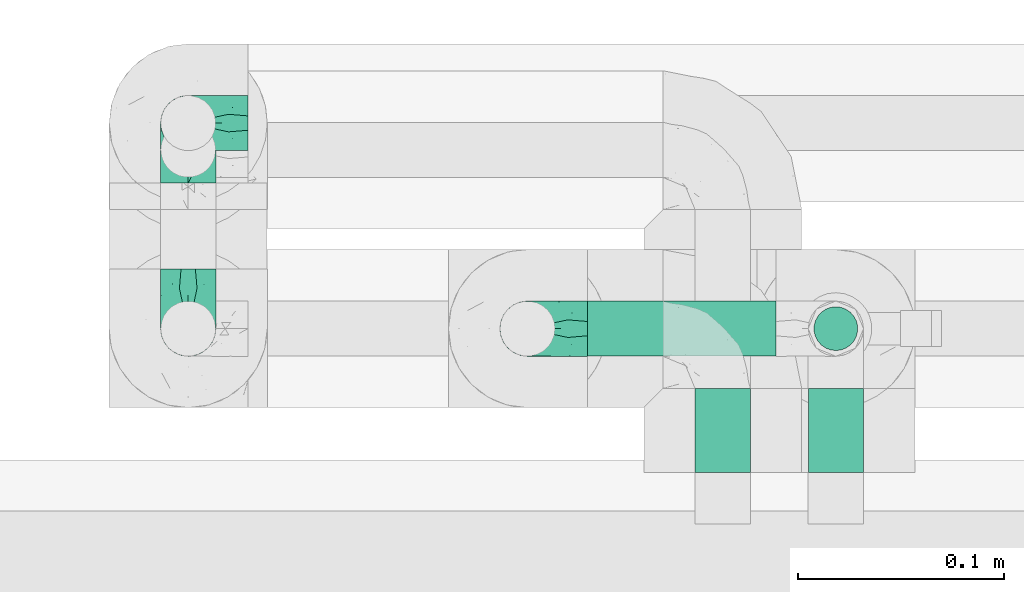
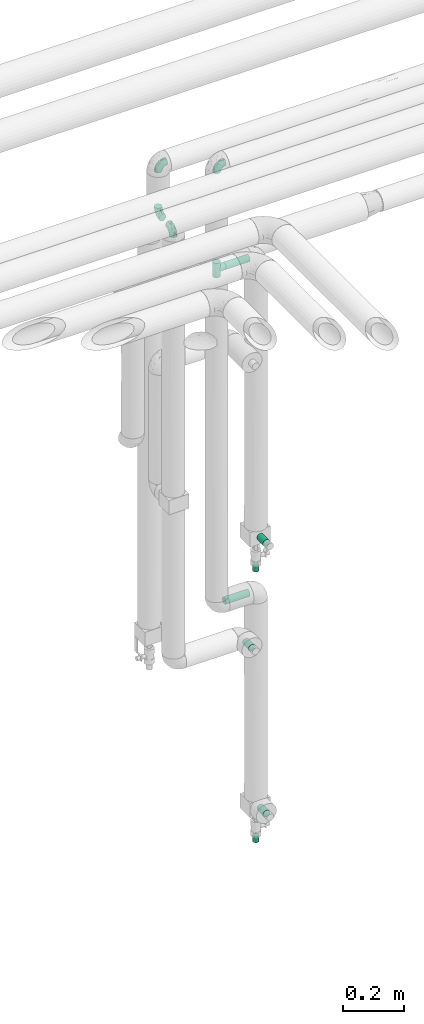
# One storey, part 759 of 827: 7 flow fittings, 5 flow segments.
"""IFC2X3 building model written with IfcOpenShell, lengths in millimetres."""

import ifcopenshell
import ifcopenshell.guid

model = None  # the IFC model being written
_history = None  # IfcOwnerHistory: only IFC2X3 demands one
_inside = {}  # id of a spatial element -> (the spatial element, [elements in it])
_under = {}  # id of a project, library or spatial element -> (it, [spatial elements below it])
_declared = {}  # id of a project -> (the project, [libraries it declares])
_typed = {}  # id of a type object -> (the type object, [elements of that type])
_made_of = {}  # id of a material, layer set ... -> (it, [elements and type objects made of it])


def new_model(schema):
    """Start an empty IFC model of exactly this schema.

    Asked for "IFC4X3", IfcOpenShell would pick the latest addendum, in which some entities
    have other attributes; the version numbers below select the first issue.
    IFC2X3 requires an IfcOwnerHistory on every rooted entity: one is made here for all.
    """
    global model, _history
    if schema == "IFC4X3":
        model = ifcopenshell.file(schema_version=(4, 3, 0, 0))
    else:
        model = ifcopenshell.file(schema=schema)
    _inside.clear()
    _under.clear()
    _declared.clear()
    _typed.clear()
    _made_of.clear()
    _history = None
    if model.schema == "IFC2X3":
        org = make("IfcOrganization", Name="unknown")
        user = make(
            "IfcPersonAndOrganization",
            ThePerson=make("IfcPerson", FamilyName="unknown"),
            TheOrganization=org,
        )
        app = make(
            "IfcApplication",
            ApplicationDeveloper=org,
            Version="unknown",
            ApplicationFullName="unknown",
            ApplicationIdentifier="unknown",
        )
        _history = make(
            "IfcOwnerHistory",
            OwningUser=user,
            OwningApplication=app,
            ChangeAction="ADDED",
            CreationDate=0,
        )
    return model


def make(cls, **values):
    """One entity of the class cls with the attributes given. An attribute that is None is left unset."""
    return model.create_entity(
        cls, **{name: value for name, value in values.items() if value is not None}
    )


def entity(cls, *values):
    """Any entity or typed value of the class cls, its attributes in the order of the schema. None: left unset."""
    e = model.create_entity(cls)
    for i, value in enumerate(values):
        if value is not None:
            e[i] = value
    return e


def rooted(cls, **values):
    """An entity with a GlobalId (a new one), such as an element, a storey or a relation."""
    return make(cls, GlobalId=ifcopenshell.guid.new(), OwnerHistory=_history, **values)


def si_unit(unit_type, name, prefix=None):
    """IfcSIUnit, for example si_unit("LENGTHUNIT", "METRE", prefix="MILLI")."""
    return make("IfcSIUnit", UnitType=unit_type, Prefix=prefix, Name=name)


def converted_unit(unit_type, name, factor, base, dimensions=None, offset=None):
    """IfcConversionBasedUnit, such as the inch: factor (a typed value) times the base unit."""
    return make(
        "IfcConversionBasedUnit"
        if offset is None
        else "IfcConversionBasedUnitWithOffset",
        ConversionOffset=offset,
        Dimensions=None
        if dimensions is None
        else entity("IfcDimensionalExponents", *dimensions),
        UnitType=unit_type,
        Name=name,
        ConversionFactor=make(
            "IfcMeasureWithUnit", ValueComponent=factor, UnitComponent=base
        ),
    )


def derived_unit(unit_type, elements):
    """IfcDerivedUnit: a product of units, each with its exponent."""
    return make(
        "IfcDerivedUnit",
        Elements=[
            make("IfcDerivedUnitElement", Unit=unit, Exponent=power)
            for unit, power in elements
        ],
        UnitType=unit_type,
    )


def assignment(units):
    """IfcUnitAssignment: the units of a project."""
    return None if units is None else make("IfcUnitAssignment", Units=units)


def point(xyz):
    """IfcCartesianPoint."""
    return None if xyz is None else make("IfcCartesianPoint", Coordinates=xyz)


def direction(xyz):
    """IfcDirection."""
    return None if xyz is None else make("IfcDirection", DirectionRatios=xyz)


def frame(location, z_axis=None, x_axis=None):
    """IfcAxis2Placement3D, a coordinate frame: its origin and axes. An axis left out is left unset."""
    return make(
        "IfcAxis2Placement3D",
        Location=point(location),
        Axis=direction(z_axis),
        RefDirection=direction(x_axis),
    )


def frame_2d(location, x_axis=None):
    """IfcAxis2Placement2D, a coordinate frame in the plane: its origin and x axis."""
    return make(
        "IfcAxis2Placement2D", Location=point(location), RefDirection=direction(x_axis)
    )


def origin():
    """The frame at (0, 0, 0) with its axes left unset."""
    return frame((0.0, 0.0, 0.0))


def origin_2d_with_axis():
    """The frame at (0, 0) in the plane with the x axis (1, 0) written out."""
    return frame_2d((0.0, 0.0), x_axis=(1.0, 0.0))


def place(relative_to, where):
    """IfcLocalPlacement: puts the frame where relative to a parent placement (None: the world)."""
    return make(
        "IfcLocalPlacement", PlacementRelTo=relative_to, RelativePlacement=where
    )


def context(
    kind, dimensions, precision=None, world=None, true_north=None, identifier=None
):
    """IfcGeometricRepresentationContext, for example the 3D "Model" context."""
    return make(
        "IfcGeometricRepresentationContext",
        ContextIdentifier=identifier,
        ContextType=kind,
        CoordinateSpaceDimension=dimensions,
        Precision=precision,
        WorldCoordinateSystem=world,
        TrueNorth=true_north,
    )


def subcontext(parent, identifier, kind, view, scale=None):
    """IfcGeometricRepresentationSubContext, for example "Body" below "Model"."""
    return make(
        "IfcGeometricRepresentationSubContext",
        ContextIdentifier=identifier,
        ContextType=kind,
        ParentContext=parent,
        TargetScale=scale,
        TargetView=view,
    )


def project(units=None, contexts=None):
    """IfcProject with its units and contexts."""
    return rooted(
        "IfcProject",
        Name="project",
        RepresentationContexts=contexts,
        UnitsInContext=assignment(units),
    )


def spatial(cls, under=None, at=None, **own):
    """A site, building, storey or space (cls), placed at a placement, below another one or the project."""
    s = rooted(cls, ObjectPlacement=at, **own)
    if under is not None:
        _under.setdefault(under.id(), (under, []))[1].append(s)
    return s


def profile(cls, at=None, kind="AREA", **sizes):
    """A parametric profile (cls). Its sizes go by their IFC names, for example OverallWidth=200.0."""
    return make(cls, ProfileType=kind, Position=at, **sizes)


def circle(**sizes):
    """IfcCircleProfileDef."""
    return profile("IfcCircleProfileDef", **sizes)


def extrude(swept, where, along, depth):
    """IfcExtrudedAreaSolid: the profile swept, set in the frame where, extruded along a direction by depth."""
    return make(
        "IfcExtrudedAreaSolid",
        SweptArea=swept,
        Position=where,
        ExtrudedDirection=direction(along),
        Depth=depth,
    )


def faces_of(points, faces, orient=None, outer=None):
    """IfcFace entities. A face is a list of loops; a loop is a list of indices into points, from 0.

    orient and outer hold one flag for each loop. By default every Orientation is true, the
    first loop of a face is its IfcFaceOuterBound and the others are IfcFaceBound.
    """
    made = []
    for i, loops in enumerate(faces):
        bounds = []
        for j, loop in enumerate(loops):
            is_outer = j == 0 if outer is None else outer[i][j]
            bounds.append(
                make(
                    "IfcFaceOuterBound" if is_outer else "IfcFaceBound",
                    Bound=make("IfcPolyLoop", Polygon=[points[k] for k in loop]),
                    Orientation=True if orient is None else orient[i][j],
                )
            )
        made.append(make("IfcFace", Bounds=bounds))
    return made


def faceted_brep(points, faces, orient=None, outer=None, voids=None):
    """IfcFacetedBrep: a solid bounded by flat faces; with voids (closed shells), ...WithVoids."""
    shared = [point(p) for p in points]
    hull = make("IfcClosedShell", CfsFaces=faces_of(shared, faces, orient, outer))
    if voids is None:
        return make("IfcFacetedBrep", Outer=hull)
    return make(
        "IfcFacetedBrepWithVoids",
        Outer=hull,
        Voids=[
            make(cls, CfsFaces=faces_of(shared, fs, o, b)) for cls, fs, o, b in voids
        ],
    )


def shape(context_of_items, identifier, shape_type, items):
    """IfcShapeRepresentation: the items that make up one representation, for example the "Body"."""
    return make(
        "IfcShapeRepresentation",
        ContextOfItems=context_of_items,
        RepresentationIdentifier=identifier,
        RepresentationType=shape_type,
        Items=items,
    )


def source(mapping_origin, context_of_items, identifier, shape_type, items):
    """IfcRepresentationMap: a shape defined once, which mapped items show again and again."""
    return make(
        "IfcRepresentationMap",
        MappingOrigin=mapping_origin,
        MappedRepresentation=shape(context_of_items, identifier, shape_type, items),
    )


def transform(
    local_origin,
    x_axis=None,
    y_axis=None,
    z_axis=None,
    scale=None,
    scale2=None,
    scale3=None,
    uniform=True,
):
    """IfcCartesianTransformationOperator3D, or its non-uniform kind. x_axis, y_axis, z_axis: its Axis1, 2, 3."""
    if uniform:
        return make(
            "IfcCartesianTransformationOperator3D",
            Axis1=direction(x_axis),
            Axis2=direction(y_axis),
            LocalOrigin=point(local_origin),
            Scale=scale,
            Axis3=direction(z_axis),
        )
    return make(
        "IfcCartesianTransformationOperator3DnonUniform",
        Axis1=direction(x_axis),
        Axis2=direction(y_axis),
        LocalOrigin=point(local_origin),
        Scale=scale,
        Axis3=direction(z_axis),
        Scale2=scale2,
        Scale3=scale3,
    )


def mapped(mapping_source, mapping_target):
    """IfcMappedItem: shows the shape of a source again, moved by a transform."""
    return make(
        "IfcMappedItem", MappingSource=mapping_source, MappingTarget=mapping_target
    )


def material(Name=None, Category=None):
    """IfcMaterial."""
    return make("IfcMaterial", Name=Name, Category=Category)


def made_of(thing, what):
    """Note that an element or type object is made of a material, layer set ...; save() writes the relation."""
    if what is not None:
        _made_of.setdefault(what.id(), (what, []))[1].append(thing)
    return thing


def type_object(cls, material=None, **own):
    """A type object (cls), such as IfcWallType, which elements share."""
    return made_of(rooted(cls, **own), material)


def type_shapes(of_type, sources):
    """Give a type object the sources (RepresentationMaps) that its elements show as mapped items."""
    of_type.RepresentationMaps = sources


def element(
    cls,
    number,
    at=None,
    inside=None,
    cuts=None,
    type_object=None,
    material=None,
    context=None,
    identifier="Body",
    shape_type=None,
    held_by="IfcProductDefinitionShape",
    body=None,
    shapes=None,
    **own,
):
    """One element of the class cls, such as IfcWall. Its Tag is "e" and its number.

    at: its placement. inside: the storey or other place that contains it. cuts: it is an
    opening in that element (IfcRelVoidsElement). A single representation is given by context,
    identifier, shape_type and body (its items); several are given by shapes. held_by: the class
    of the entity that holds the representations. save() writes the other relations.
    """
    e = rooted(cls, Tag="e%d" % number, ObjectPlacement=at, **own)
    if body is not None:
        shapes = [shape(context, identifier, shape_type, body)]
    if shapes is not None:
        e.Representation = make(held_by, Representations=shapes)
    if inside is not None:
        _inside.setdefault(inside.id(), (inside, []))[1].append(e)
    if cuts is not None:
        rooted(
            "IfcRelVoidsElement", RelatingBuildingElement=cuts, RelatedOpeningElement=e
        )
    if type_object is not None:
        _typed.setdefault(type_object.id(), (type_object, []))[1].append(e)
    return made_of(e, material)


def aggregate(whole, parts):
    """IfcRelAggregates: a whole, such as a stair, and the parts it consists of."""
    return rooted("IfcRelAggregates", RelatingObject=whole, RelatedObjects=parts)


def save(model, path):
    """Write the relations noted so far, then the file.

    IfcRelAggregates (storeys below a building ...), IfcRelContainedInSpatialStructure (elements
    in a storey), IfcRelDefinesByType, IfcRelAssociatesMaterial and IfcRelDeclares: one each for
    every whole, place, type object, material and project.
    """
    for whole, parts in _under.values():
        aggregate(whole, parts)
    for where, things in _inside.values():
        rooted(
            "IfcRelContainedInSpatialStructure",
            RelatedElements=things,
            RelatingStructure=where,
        )
    for kind, things in _typed.values():
        rooted("IfcRelDefinesByType", RelatedObjects=things, RelatingType=kind)
    for what, things in _made_of.values():
        rooted("IfcRelAssociatesMaterial", RelatedObjects=things, RelatingMaterial=what)
    for by, libraries in _declared.values():
        rooted("IfcRelDeclares", RelatingContext=by, RelatedDefinitions=libraries)
    model.write(path)


model = new_model("IFC2X3")

# Units and contexts
model_context = context("Model", 3, precision=0.01, world=origin(), true_north=direction((6.12303176911189e-17, 1.0)))
body_context = subcontext(model_context, "Body", "Model", "MODEL_VIEW")
ifc_project = project(units=[si_unit("LENGTHUNIT", "METRE", prefix="MILLI"), si_unit("AREAUNIT", "SQUARE_METRE"), si_unit("VOLUMEUNIT", "CUBIC_METRE"), converted_unit("PLANEANGLEUNIT", "DEGREE", entity("IfcRatioMeasure", 0.0174532925199433), si_unit("PLANEANGLEUNIT", "RADIAN"), dimensions=[0, 0, 0, 0, 0, 0, 0]), si_unit("MASSUNIT", "GRAM", prefix="KILO"), derived_unit("MASSDENSITYUNIT", [(si_unit("MASSUNIT", "GRAM", prefix="KILO"), 1), (si_unit("LENGTHUNIT", "METRE"), -3)]), derived_unit("MOMENTOFINERTIAUNIT", [(si_unit("LENGTHUNIT", "METRE"), 4)]), si_unit("TIMEUNIT", "SECOND"), si_unit("FREQUENCYUNIT", "HERTZ"), si_unit("THERMODYNAMICTEMPERATUREUNIT", "DEGREE_CELSIUS"), derived_unit("THERMALTRANSMITTANCEUNIT", [(si_unit("MASSUNIT", "GRAM", prefix="KILO"), 1), (si_unit("THERMODYNAMICTEMPERATUREUNIT", "KELVIN"), -1), (si_unit("TIMEUNIT", "SECOND"), -3)]), derived_unit("VOLUMETRICFLOWRATEUNIT", [(si_unit("LENGTHUNIT", "METRE"), 3), (si_unit("TIMEUNIT", "SECOND"), -1)]), derived_unit("MASSFLOWRATEUNIT", [(si_unit("MASSUNIT", "GRAM", prefix="KILO"), 1), (si_unit("TIMEUNIT", "SECOND"), -1)]), derived_unit("ROTATIONALFREQUENCYUNIT", [(si_unit("TIMEUNIT", "SECOND"), -1)]), si_unit("ELECTRICCURRENTUNIT", "AMPERE"), si_unit("ELECTRICVOLTAGEUNIT", "VOLT"), si_unit("POWERUNIT", "WATT"), si_unit("FORCEUNIT", "NEWTON", prefix="KILO"), si_unit("ILLUMINANCEUNIT", "LUX"), si_unit("LUMINOUSFLUXUNIT", "LUMEN"), si_unit("LUMINOUSINTENSITYUNIT", "CANDELA"), derived_unit("USERDEFINED", [(si_unit("MASSUNIT", "GRAM", prefix="KILO"), -1), (si_unit("LENGTHUNIT", "METRE"), -2), (si_unit("TIMEUNIT", "SECOND"), 3), (si_unit("LUMINOUSFLUXUNIT", "LUMEN"), 1)]), derived_unit("LINEARVELOCITYUNIT", [(si_unit("LENGTHUNIT", "METRE"), 1), (si_unit("TIMEUNIT", "SECOND"), -1)]), si_unit("PRESSUREUNIT", "PASCAL"), derived_unit("USERDEFINED", [(si_unit("LENGTHUNIT", "METRE"), -2), (si_unit("MASSUNIT", "GRAM", prefix="KILO"), 1), (si_unit("TIMEUNIT", "SECOND"), -2)]), derived_unit("LINEARFORCEUNIT", [(si_unit("MASSUNIT", "GRAM", prefix="KILO"), 1), (si_unit("LENGTHUNIT", "METRE"), 1), (si_unit("TIMEUNIT", "SECOND"), -2), (si_unit("LENGTHUNIT", "METRE"), -1)]), derived_unit("PLANARFORCEUNIT", [(si_unit("MASSUNIT", "GRAM", prefix="KILO"), 1), (si_unit("LENGTHUNIT", "METRE"), 1), (si_unit("TIMEUNIT", "SECOND"), -2), (si_unit("LENGTHUNIT", "METRE"), -2)])], contexts=[model_context])

# Site, building, storey
site_placement = place(None, origin())
site = spatial("IfcSite", under=ifc_project, at=site_placement, CompositionType="ELEMENT")
building_placement = place(site_placement, origin())
building = spatial("IfcBuilding", under=site, at=building_placement, CompositionType="ELEMENT")
storey_placement = place(building_placement, frame((0.0, 0.0, 28200.0)))
storey = spatial("IfcBuildingStorey", under=building, at=storey_placement, Name="08", CompositionType="ELEMENT", Elevation=28200.0)

# Flow segments
pipe_segment_type = type_object("IfcPipeSegmentType", PredefinedType="NOTDEFINED")
flow_segment_1_placement = place(storey_placement, frame((34719.52, 18319.92, 1215.0)))
element("IfcFlowSegment", 1, at=flow_segment_1_placement, inside=storey, type_object=pipe_segment_type, context=body_context, shape_type="SweptSolid", body=[
    extrude(circle(Radius=13.4, at=origin_2d_with_axis()), frame((0.0, 15.0, 15.0), z_axis=(1.0, 0.0, 0.0), x_axis=(0.0, 1.0, 0.0)), (0.0, 0.0, 1.0), 91.8000000000181),
])
flow_segment_2_placement = place(storey_placement, frame((34770.39, 18264.91, 1045.0)))
element("IfcFlowSegment", 2, at=flow_segment_2_placement, inside=storey, type_object=pipe_segment_type, context=body_context, shape_type="SweptSolid", body=[
    extrude(circle(Radius=13.4, at=origin_2d_with_axis()), frame((15.0, 0.0, 15.0), z_axis=(0.0, 1.0, 0.0), x_axis=(-1.0, 0.0, 0.0)), (0.0, 0.0, 1.0), 40.9000000000037),
])
flow_segment_3_placement = place(storey_placement, frame((34825.43, 18264.91, 357.0)))
element("IfcFlowSegment", 3, at=flow_segment_3_placement, inside=storey, type_object=pipe_segment_type, context=body_context, shape_type="SweptSolid", body=[
    extrude(circle(Radius=13.4, at=origin_2d_with_axis()), frame((15.0, 0.0, 15.0), z_axis=(0.0, 1.0, 0.0), x_axis=(-1.0, 0.0, 0.0)), (0.0, 0.0, 1.0), 40.9999999999993),
])
flow_segment_4_placement = place(storey_placement, frame((34825.43, 18264.91, 1448.5)))
element("IfcFlowSegment", 4, at=flow_segment_4_placement, inside=storey, type_object=pipe_segment_type, context=body_context, shape_type="SweptSolid", body=[
    extrude(circle(Radius=13.4, at=origin_2d_with_axis()), frame((15.0, 0.0, 15.0), z_axis=(0.0, 1.0, 0.0), x_axis=(-1.0, 0.0, 0.0)), (0.0, 0.0, 1.0), 40.9999999999928),
])
flow_segment_5_placement = place(storey_placement, frame((34719.42, 18319.92, 2565.0)))
element("IfcFlowSegment", 5, at=flow_segment_5_placement, inside=storey, type_object=pipe_segment_type, context=body_context, shape_type="SweptSolid", body=[
    extrude(circle(Radius=13.4, at=origin_2d_with_axis()), frame((0.0, 15.0, 15.0), z_axis=(1.0, 0.0, 0.0), x_axis=(0.0, 1.0, 0.0)), (0.0, 0.0, 1.0), 91.9000000000224),
])

# Flow fittings
ifc_material = material()
pipe_fitting_type_1 = type_object("IfcPipeFittingType", PredefinedType="NOTDEFINED", material=ifc_material)
shared_shape_1 = source(origin(), body_context, "Body", "SweptSolid", [
    extrude(circle(Radius=10.65, at=origin_2d_with_axis()), frame((0.0, 0.0, 0.0), z_axis=(1.0, 0.0, 0.0), x_axis=(0.0, 1.0, 0.0)), (0.0, 0.0, 1.0), 25.0000000000003),
])
type_shapes(pipe_fitting_type_1, [shared_shape_1])
for number, where, z_axis, x_axis in (
    (6, (34840.42, 18334.91, 244.0), (1.0, 0.0, 0.0), (0.0, 0.0, -1.0)),
    (7, (34840.42, 18334.91, 1335.5), (1.0, 0.0, 0.0), (0.0, 0.0, -1.0)),
):
    element("IfcFlowFitting", number, at=place(storey_placement, frame(where, z_axis=z_axis, x_axis=x_axis)), inside=storey, type_object=pipe_fitting_type_1, material=ifc_material, context=body_context, shape_type="MappedRepresentation", body=[
        mapped(shared_shape_1, transform((0.0, 0.0, 0.0), scale=1.0)),
    ])
pipe_fitting_type_2 = type_object("IfcPipeFittingType", Name="ADSK_1", PredefinedType="NOTDEFINED", material=ifc_material)
shared_shape_2 = source(origin(), body_context, "Body", "Brep", [
    faceted_brep([(-29.1, 0.0, -13.45), (-29.1, -3.48, -12.99), (-29.1, -6.73, -11.65), (-29.1, -9.51, -9.51), (-29.1, -11.65, -6.73), (-29.1, -12.99, -3.48), (-29.1, -13.45, 0.0), (-29.1, -12.99, 3.48), (-29.1, -11.65, 6.72), (-29.1, -9.51, 9.51), (-29.1, -6.73, 11.65), (-29.1, -3.48, 12.99), (-29.1, 0.0, 13.45), (-29.1, 3.48, 12.99), (-29.1, 6.72, 11.65), (-29.1, 9.51, 9.51), (-29.1, 11.65, 6.72), (-29.1, 12.99, 3.48), (-29.1, 13.45, 0.0), (-29.1, 12.99, -3.48), (-29.1, 11.65, -6.73), (-29.1, 9.51, -9.51), (-29.1, 6.72, -11.65), (-29.1, 3.48, -12.99), (-3.48, 29.1, -12.99), (-6.72, 29.1, -11.65), (-9.51, 29.1, -9.51), (-11.65, 29.1, -6.73), (-12.99, 29.1, -3.48), (-13.45, 29.1, 0.0), (-12.99, 29.1, 3.48), (-11.65, 29.1, 6.72), (-9.51, 29.1, 9.51), (-6.72, 29.1, 11.65), (-3.48, 29.1, 12.99), (0.0, 29.1, 13.45), (3.48, 29.1, 12.99), (6.73, 29.1, 11.65), (9.51, 29.1, 9.51), (11.65, 29.1, 6.72), (12.99, 29.1, 3.48), (13.45, 29.1, 0.0), (12.99, 29.1, -3.48), (11.65, 29.1, -6.73), (9.51, 29.1, -9.51), (6.73, 29.1, -11.65), (3.48, 29.1, -12.99), (0.0, 29.1, -13.45), (-19.62, -11.66, 4.28), (-21.41, -10.36, 7.6), (-16.26, -10.01, 0.0), (-12.48, -9.76, 2.75), (-10.66, 15.6, 11.91), (-15.27, 9.55, 12.42), (-10.71, 10.71, 13.09), (-0.04, 0.04, 0.0), (0.49, -0.45, 4.38), (-3.67, -4.15, 4.26), (-22.68, -11.73, 0.0), (-21.45, -4.97, 12.13), (-11.59, -2.84, 11.28), (-14.77, 0.17, 13.07), (-19.08, -7.58, 10.06), (-22.36, -1.69, 13.23), (-20.49, 2.21, 13.42), (-7.82, -7.75, 0.0), (-5.53, -2.55, 8.58), (-1.33, -0.87, 6.53), (-1.15, 1.15, 8.49), (-22.46, 5.38, 12.69), (-14.04, 21.05, 6.04), (-3.19, 3.19, 11.14), (-5.08, 25.05, 12.59), (-1.97, 21.79, 13.41), (-22.68, 11.31, 8.78), (-18.16, 12.64, 9.68), (-20.46, 14.33, 6.11), (-4.13, 10.11, 13.26), (-7.66, 3.08, 12.63), (-2.02, 8.24, 12.45), (-24.91, 8.22, 10.95), (-5.08, 14.28, 13.42), (-8.96, 6.48, 13.4), (-19.7, 16.14, 3.1), (-18.03, 18.03, 0.0), (-23.05, 15.96, 0.0), (-25.26, 12.69, 5.56), (4.97, 21.45, 12.13), (7.58, 19.08, 10.06), (1.69, 22.36, 13.23), (10.36, 21.41, 7.6), (8.11, 12.69, 6.86), (11.66, 19.62, 4.28), (-6.03, 19.65, 12.79), (9.76, 12.48, 2.75), (10.01, 16.26, 0.0), (-14.58, 16.06, 9.44), (-11.19, 23.14, 8.74), (-16.29, 16.8, 7.24), (-11.99, -5.68, 9.36), (-15.42, 20.78, 3.08), (5.79, 12.02, 9.27), (2.84, 11.59, 11.28), (2.55, 5.53, 8.58), (-15.74, 23.57, 0.0), (-15.96, 23.05, 0.0), (-24.62, 13.88, 2.39), (-8.61, 22.49, 11.12), (-14.98, 12.8, 11.14), (11.73, 22.68, 0.0), (-12.69, -8.11, 6.86), (7.75, 7.82, 0.0), (-15.98, 6.12, 13.19), (-14.48, 3.64, 13.45), (-19.6, 9.46, 11.31), (-8.3, 15.02, 12.85), (-0.17, 14.77, 13.07), (-6.9, -5.2, 6.52), (7.5, 8.93, 4.46), (5.22, 6.95, 6.56), (-8.85, -7.47, 4.42), (3.86, 3.93, 0.0), (4.18, 3.75, 4.31), (-23.57, 15.74, 0.0), (-3.93, -3.86, 0.0), (-21.79, 1.97, -13.41), (-11.31, 22.68, -8.78), (-14.33, 20.46, -6.11), (-12.69, 25.26, -5.56), (4.97, 21.45, -12.13), (2.84, 11.59, -11.28), (-0.17, 14.77, -13.07), (-25.05, 5.08, -12.59), (-16.8, 16.29, -7.24), (-20.78, 15.42, -3.08), (-16.14, 19.7, -3.1), (-12.02, -5.79, -9.27), (-11.59, -2.84, -11.28), (-5.53, -2.55, -8.58), (-23.14, 11.19, -8.74), (-22.49, 8.61, -11.12), (-1.33, -0.87, -6.53), (-3.67, -4.15, -4.26), (-6.9, -5.2, -6.52), (-19.65, 6.03, -12.79), (-15.6, 10.66, -11.91), (-14.28, 5.08, -13.42), (-10.71, 10.71, -13.09), (-6.48, 8.96, -13.4), (-19.62, -11.66, -4.28), (-21.41, -10.36, -7.6), (-12.48, -9.76, -2.75), (11.66, 19.62, -4.28), (-12.69, -8.11, -6.86), (-22.36, -1.69, -13.23), (-16.06, 14.58, -9.44), (5.68, 11.99, -9.36), (7.58, 19.08, -10.06), (-19.08, -7.58, -10.06), (-21.45, -4.97, -12.13), (-9.55, 15.27, -12.42), (-12.8, 14.98, -11.14), (-8.22, 24.91, -10.95), (10.36, 21.41, -7.6), (-5.38, 22.46, -12.69), (1.69, 22.36, -13.23), (-2.21, 20.49, -13.42), (-12.64, 18.16, -9.68), (-21.05, 14.04, -6.04), (9.76, 12.48, -2.75), (-10.11, 4.13, -13.26), (-3.08, 7.66, -12.63), (-8.24, 2.02, -12.45), (-13.88, 24.62, -2.39), (8.11, 12.69, -6.86), (-6.12, 15.98, -13.19), (-3.64, 14.48, -13.45), (-9.46, 19.6, -11.31), (-15.02, 8.3, -12.85), (-14.77, 0.17, -13.07), (-3.19, 3.19, -11.14), (5.22, 6.95, -6.56), (2.55, 5.53, -8.58), (0.49, -0.45, -4.38), (4.18, 3.75, -4.31), (-8.85, -7.47, -4.42), (-1.15, 1.15, -8.49), (7.5, 8.93, -4.46)], [[[0, 1, 2, 3, 4, 5, 6, 7, 8, 9, 10, 11, 12, 13, 14, 15, 16, 17, 18, 19, 20, 21, 22, 23]], [[24, 25, 26, 27, 28, 29, 30, 31, 32, 33, 34, 35, 36, 37, 38, 39, 40, 41, 42, 43, 44, 45, 46, 47]], [[48, 49, 8]], [[48, 50, 51]], [[52, 53, 54]], [[55, 56, 57]], [[49, 9, 8]], [[58, 48, 7]], [[59, 60, 61]], [[62, 10, 9]], [[62, 59, 10]], [[12, 63, 64]], [[51, 50, 65]], [[66, 67, 68]], [[12, 11, 63]], [[69, 14, 13]], [[31, 30, 70]], [[66, 71, 60]], [[34, 72, 73]], [[74, 75, 76]], [[77, 78, 79]], [[14, 80, 15]], [[16, 15, 74]], [[81, 54, 82]], [[83, 84, 85]], [[74, 76, 86]], [[37, 87, 88]], [[88, 38, 37]], [[36, 35, 89]], [[90, 91, 92]], [[93, 81, 73]], [[35, 34, 73]], [[10, 59, 11]], [[92, 94, 95]], [[96, 97, 98]], [[90, 92, 39]], [[99, 60, 62]], [[40, 39, 92]], [[87, 37, 36]], [[100, 84, 83]], [[50, 48, 58]], [[100, 83, 98]], [[101, 102, 103]], [[104, 105, 84, 100, 29]], [[48, 8, 7]], [[86, 17, 16]], [[106, 18, 17]], [[32, 97, 107]], [[53, 52, 108]], [[52, 93, 107]], [[97, 96, 107]], [[72, 107, 93]], [[72, 34, 33]], [[92, 109, 40]], [[33, 32, 107]], [[69, 13, 64]], [[88, 87, 102]], [[12, 64, 13]], [[49, 110, 62]], [[39, 38, 90]], [[95, 94, 111]], [[112, 113, 82]], [[53, 69, 112]], [[80, 74, 15]], [[114, 108, 75]], [[32, 31, 97]], [[115, 52, 54]], [[93, 115, 81]], [[89, 73, 116]], [[106, 76, 83]], [[106, 83, 85]], [[83, 76, 98]], [[100, 30, 29]], [[60, 59, 62]], [[63, 59, 61]], [[110, 117, 99]], [[60, 71, 78]], [[89, 87, 36]], [[116, 79, 102]], [[116, 102, 87]], [[102, 71, 103]], [[110, 49, 48]], [[62, 9, 49]], [[38, 88, 90]], [[91, 90, 88]], [[112, 69, 64]], [[80, 69, 114]], [[111, 94, 118]], [[119, 101, 103]], [[117, 66, 99]], [[117, 120, 57]], [[119, 91, 101]], [[66, 68, 71]], [[66, 117, 67]], [[121, 111, 122, 55]], [[56, 55, 122]], [[31, 70, 97]], [[97, 70, 98]], [[107, 96, 52]], [[53, 108, 114]], [[112, 82, 54]], [[116, 73, 81]], [[78, 82, 61]], [[81, 82, 77]], [[73, 89, 35]], [[87, 89, 116]], [[59, 63, 11]], [[64, 63, 61]], [[112, 64, 113]], [[53, 112, 54]], [[7, 6, 58]], [[109, 92, 95]], [[109, 41, 40]], [[69, 53, 114]], [[52, 96, 108]], [[75, 108, 96]], [[75, 96, 98]], [[114, 75, 74]], [[64, 61, 113]], [[61, 82, 113]], [[91, 88, 101]], [[110, 48, 51]], [[92, 91, 94]], [[91, 119, 118]], [[106, 85, 123, 18]], [[106, 17, 86]], [[60, 78, 61]], [[79, 78, 71]], [[102, 79, 71]], [[77, 79, 116]], [[81, 77, 116]], [[78, 77, 82]], [[69, 80, 14]], [[74, 80, 114]], [[74, 86, 16]], [[106, 86, 76]], [[107, 72, 33]], [[73, 72, 93]], [[98, 70, 100]], [[75, 98, 76]], [[30, 100, 70]], [[110, 99, 62]], [[66, 60, 99]], [[120, 110, 51]], [[67, 117, 57]], [[57, 56, 67]], [[67, 122, 119]], [[110, 120, 117]], [[65, 120, 51]], [[57, 65, 124, 55]], [[122, 67, 56]], [[67, 103, 68]], [[71, 68, 103]], [[65, 57, 120]], [[102, 101, 88]], [[67, 119, 103]], [[118, 119, 122]], [[118, 122, 111]], [[91, 118, 94]], [[81, 115, 54]], [[93, 52, 115]], [[23, 125, 0]], [[126, 127, 128]], [[129, 130, 131]], [[23, 22, 132]], [[133, 134, 135]], [[136, 137, 138]], [[21, 139, 140]], [[141, 142, 143]], [[144, 140, 145]], [[143, 136, 138]], [[146, 147, 148]], [[144, 132, 140]], [[5, 4, 149]], [[4, 3, 150]], [[45, 129, 46]], [[151, 50, 149]], [[152, 43, 42]], [[42, 41, 109]], [[150, 149, 4]], [[153, 149, 150]], [[154, 1, 0]], [[139, 155, 140]], [[156, 130, 157]], [[149, 58, 5]], [[18, 123, 85, 84, 134]], [[158, 159, 137]], [[84, 105, 135]], [[160, 145, 161]], [[143, 153, 136]], [[27, 26, 126]], [[25, 162, 26]], [[152, 163, 43]], [[25, 24, 164]], [[47, 165, 166]], [[158, 3, 2]], [[167, 127, 126]], [[20, 19, 168]], [[47, 46, 165]], [[44, 157, 45]], [[23, 132, 125]], [[44, 43, 163]], [[158, 2, 159]], [[47, 166, 24]], [[129, 45, 157]], [[164, 24, 166]], [[134, 84, 135]], [[95, 169, 152]], [[22, 21, 140]], [[144, 146, 125]], [[109, 152, 42]], [[95, 152, 109]], [[170, 171, 172]], [[155, 139, 133]], [[28, 27, 128]], [[159, 2, 1]], [[173, 29, 28]], [[50, 151, 65]], [[169, 95, 111]], [[163, 174, 157]], [[175, 176, 148]], [[160, 164, 175]], [[162, 126, 26]], [[177, 161, 167]], [[21, 20, 139]], [[144, 145, 178]], [[144, 178, 146]], [[154, 125, 179]], [[173, 127, 135]], [[173, 135, 105]], [[135, 127, 133]], [[134, 19, 18]], [[154, 159, 1]], [[179, 172, 137]], [[179, 137, 159]], [[137, 180, 138]], [[130, 129, 157]], [[165, 129, 131]], [[174, 181, 156]], [[130, 180, 171]], [[3, 158, 150]], [[153, 150, 158]], [[174, 163, 152]], [[157, 44, 163]], [[175, 164, 166]], [[162, 164, 177]], [[130, 182, 180]], [[181, 141, 182]], [[55, 183, 184]], [[65, 151, 185]], [[183, 55, 142]], [[156, 181, 182]], [[180, 182, 186]], [[181, 187, 184]], [[65, 142, 55, 124]], [[20, 168, 139]], [[139, 168, 133]], [[140, 155, 145]], [[160, 161, 177]], [[175, 148, 147]], [[179, 125, 146]], [[171, 148, 131]], [[146, 148, 170]], [[125, 154, 0]], [[159, 154, 179]], [[129, 165, 46]], [[166, 165, 131]], [[175, 166, 176]], [[160, 175, 147]], [[58, 149, 50]], [[58, 6, 5]], [[145, 160, 147]], [[164, 160, 177]], [[145, 155, 161]], [[167, 161, 155]], [[167, 155, 133]], [[177, 167, 126]], [[166, 131, 176]], [[131, 148, 176]], [[149, 153, 151]], [[153, 143, 185]], [[145, 147, 178]], [[174, 152, 169]], [[173, 105, 104, 29]], [[173, 28, 128]], [[130, 171, 131]], [[172, 171, 180]], [[137, 172, 180]], [[170, 172, 179]], [[146, 170, 179]], [[171, 170, 148]], [[164, 162, 25]], [[126, 162, 177]], [[126, 128, 27]], [[173, 128, 127]], [[140, 132, 22]], [[125, 132, 144]], [[133, 168, 134]], [[167, 133, 127]], [[19, 134, 168]], [[153, 158, 136]], [[137, 136, 158]], [[141, 143, 138]], [[185, 143, 142]], [[186, 141, 138]], [[183, 142, 141]], [[185, 142, 65]], [[153, 185, 151]], [[180, 186, 138]], [[182, 141, 186]], [[141, 184, 183]], [[184, 111, 121, 55]], [[174, 156, 157]], [[182, 130, 156]], [[187, 174, 169]], [[141, 181, 184]], [[174, 187, 181]], [[111, 187, 169]], [[111, 184, 187]], [[146, 178, 147]]]),
])
type_shapes(pipe_fitting_type_2, [shared_shape_2])
for number, where, z_axis, x_axis, name in (
    (8, (34525.39, 18334.91, 2800.0), (-1.0, 0.0, 0.0), (0.0, 0.0, 1.0), "ADSK_1"),
    (9, (34525.39, 18434.91, 2800.0), (1.0, 0.0, 0.0), (0.0, 1.0, 0.0), "ADSK_1"),
    (10, (34525.39, 18434.91, 3000.17), (0.0, 1.0, 0.0), (0.0, 0.0, 1.0), "ADSK_1"),
    (11, (34690.42, 18334.91, 3000.17), (0.0, 1.0, 0.0), (0.0, 0.0, 1.0), "ADSK_1"),
):
    element("IfcFlowFitting", number, at=place(storey_placement, frame(where, z_axis=z_axis, x_axis=x_axis)), inside=storey, type_object=pipe_fitting_type_2, material=ifc_material, Name=name, ObjectType="ADSK_1", context=body_context, shape_type="MappedRepresentation", body=[
        mapped(shared_shape_2, transform((0.0, 0.0, 0.0), scale=1.0)),
    ])
pipe_fitting_type_3 = type_object("IfcPipeFittingType", Name="ADSK_1", PredefinedType="NOTDEFINED", material=ifc_material)
shared_shape_3 = source(origin(), body_context, "Body", "Brep", [
    faceted_brep([(-29.0, 3.48, -12.99), (-29.0, 0.0, -13.45), (-29.0, -3.48, -12.99), (-29.0, -6.73, -11.65), (-29.0, -9.51, -9.51), (-29.0, -11.65, -6.73), (-29.0, -12.99, -3.48), (-29.0, -13.45, 0.0), (-29.0, -12.99, 3.48), (-29.0, -11.65, 6.72), (-29.0, -9.51, 9.51), (-29.0, -6.73, 11.65), (-29.0, -3.48, 12.99), (-29.0, 0.0, 13.45), (-29.0, 3.48, 12.99), (-29.0, 6.72, 11.65), (-29.0, 9.51, 9.51), (-29.0, 11.65, 6.72), (-29.0, 12.99, 3.48), (-29.0, 13.45, 0.0), (-29.0, 12.99, -3.48), (-29.0, 11.65, -6.73), (-29.0, 9.51, -9.51), (-29.0, 6.72, -11.65), (29.0, 11.65, -6.73), (29.0, 12.99, -3.48), (29.0, 13.45, 0.0), (29.0, 12.99, 3.48), (29.0, 11.65, 6.72), (29.0, 9.51, 9.51), (29.0, 6.72, 11.65), (29.0, 3.48, 12.99), (29.0, 0.0, 13.45), (29.0, -3.48, 12.99), (29.0, -6.73, 11.65), (29.0, -9.51, 9.51), (29.0, -11.65, 6.72), (29.0, -12.99, 3.48), (29.0, -13.45, 0.0), (29.0, -12.99, -3.48), (29.0, -11.65, -6.73), (29.0, -9.51, -9.51), (29.0, -6.73, -11.65), (29.0, -3.48, -12.99), (29.0, 0.0, -13.45), (29.0, 3.48, -12.99), (29.0, 6.72, -11.65), (29.0, 9.51, -9.51), (12.96, -12.96, 3.59), (13.45, -13.45, 0.0), (-13.45, -13.45, 0.0), (11.64, -11.64, 6.74), (7.54, -7.54, 11.14), (9.76, -9.76, 9.25), (-12.96, -12.96, 3.59), (-11.64, -11.64, 6.74), (-9.76, -9.76, 9.25), (-7.54, -7.54, 11.14), (-5.12, -5.12, 12.44), (5.12, -5.12, 12.44), (2.58, -2.58, 13.2), (0.0, 0.0, 13.45), (-2.58, -2.58, 13.2), (2.58, -2.58, -13.2), (0.0, 0.0, -13.45), (-2.58, -2.58, -13.2), (-5.12, -5.12, -12.44), (5.12, -5.12, -12.44), (7.54, -7.54, -11.14), (9.76, -9.76, -9.25), (11.64, -11.64, -6.74), (12.96, -12.96, -3.59), (-7.54, -7.54, -11.14), (-9.76, -9.76, -9.25), (-12.96, -12.96, -3.59), (-11.64, -11.64, -6.74), (-12.99, -29.0, -3.48), (-11.65, -29.0, -6.73), (-9.51, -29.0, -9.51), (-6.72, -29.0, -11.65), (-3.48, -29.0, -12.99), (0.0, -29.0, -13.45), (3.48, -29.0, -12.99), (6.73, -29.0, -11.65), (9.51, -29.0, -9.51), (11.65, -29.0, -6.73), (12.99, -29.0, -3.48), (13.45, -29.0, 0.0), (12.99, -29.0, 3.48), (11.65, -29.0, 6.72), (9.51, -29.0, 9.51), (6.73, -29.0, 11.65), (3.48, -29.0, 12.99), (0.0, -29.0, 13.45), (-3.48, -29.0, 12.99), (-6.72, -29.0, 11.65), (-9.51, -29.0, 9.51), (-11.65, -29.0, 6.72), (-12.99, -29.0, 3.48), (-13.45, -29.0, 0.0)], [[[0, 1, 2, 3, 4, 5, 6, 7, 8, 9, 10, 11, 12, 13, 14, 15, 16, 17, 18, 19, 20, 21, 22, 23]], [[24, 25, 26, 27, 28, 29, 30, 31, 32, 33, 34, 35, 36, 37, 38, 39, 40, 41, 42, 43, 44, 45, 46, 47]], [[37, 36, 48]], [[38, 37, 49]], [[50, 8, 7]], [[49, 37, 48]], [[36, 51, 48]], [[35, 34, 52]], [[51, 36, 53]], [[52, 53, 35]], [[53, 36, 35]], [[50, 54, 8]], [[8, 54, 9]], [[54, 55, 9]], [[56, 57, 10]], [[10, 9, 56]], [[10, 57, 11]], [[56, 9, 55]], [[11, 57, 58]], [[52, 34, 59]], [[60, 32, 61]], [[62, 61, 13]], [[59, 33, 60]], [[33, 59, 34]], [[60, 33, 32]], [[61, 32, 31, 14, 13]], [[28, 27, 18, 17]], [[16, 15, 30, 29]], [[17, 16, 29, 28]], [[31, 30, 15, 14]], [[19, 18, 27, 26]], [[62, 12, 58]], [[12, 62, 13]], [[58, 12, 11]], [[47, 22, 21, 24]], [[25, 20, 19, 26]], [[25, 24, 21, 20]], [[23, 22, 47, 46]], [[44, 43, 63]], [[44, 64, 1, 0, 45]], [[64, 44, 63]], [[1, 64, 65]], [[46, 45, 0, 23]], [[65, 66, 2]], [[1, 65, 2]], [[66, 3, 2]], [[63, 43, 67]], [[42, 41, 68]], [[69, 68, 41]], [[40, 70, 69]], [[69, 41, 40]], [[42, 68, 67]], [[39, 38, 49]], [[6, 50, 7]], [[39, 71, 40]], [[71, 39, 49]], [[40, 71, 70]], [[72, 3, 66]], [[72, 4, 3]], [[4, 72, 73]], [[4, 73, 5]], [[74, 50, 6]], [[75, 74, 5]], [[74, 6, 5]], [[75, 5, 73]], [[42, 67, 43]], [[76, 77, 78, 79, 80, 81, 82, 83, 84, 85, 86, 87, 88, 89, 90, 91, 92, 93, 94, 95, 96, 97, 98, 99]], [[99, 98, 50]], [[54, 50, 98]], [[96, 95, 57]], [[97, 96, 56]], [[97, 54, 98]], [[58, 95, 94]], [[55, 54, 97]], [[56, 55, 97]], [[58, 57, 95]], [[93, 61, 62]], [[58, 94, 62]], [[56, 96, 57]], [[62, 94, 93]], [[60, 93, 92]], [[91, 59, 92]], [[89, 88, 48]], [[53, 90, 89]], [[52, 91, 90]], [[49, 88, 87]], [[59, 60, 92]], [[52, 59, 91]], [[49, 48, 88]], [[51, 53, 89]], [[48, 51, 89]], [[52, 90, 53]], [[93, 60, 61]], [[87, 86, 49]], [[71, 49, 86]], [[69, 85, 84]], [[68, 84, 83]], [[86, 85, 71]], [[67, 83, 82]], [[70, 71, 85]], [[69, 70, 85]], [[67, 68, 83]], [[81, 64, 63]], [[67, 82, 63]], [[69, 84, 68]], [[63, 82, 81]], [[65, 81, 80]], [[79, 66, 80]], [[77, 76, 74]], [[73, 78, 77]], [[72, 79, 78]], [[50, 76, 99]], [[66, 65, 80]], [[72, 66, 79]], [[50, 74, 76]], [[75, 73, 77]], [[74, 75, 77]], [[72, 78, 73]], [[81, 65, 64]]]),
])
type_shapes(pipe_fitting_type_3, [shared_shape_3])
flow_fitting_placement = place(storey_placement, frame((34690.42, 18334.91, 2580.0), z_axis=(0.0, 1.0, 0.0), x_axis=(0.0, 0.0, -1.0)))
element("IfcFlowFitting", 12, at=flow_fitting_placement, inside=storey, type_object=pipe_fitting_type_3, material=ifc_material, Name="ADSK_1", ObjectType="ADSK_1", context=body_context, shape_type="MappedRepresentation", body=[
    mapped(shared_shape_3, transform((0.0, 0.0, 0.0), scale=1.0)),
])

save(model, "model.ifc")
